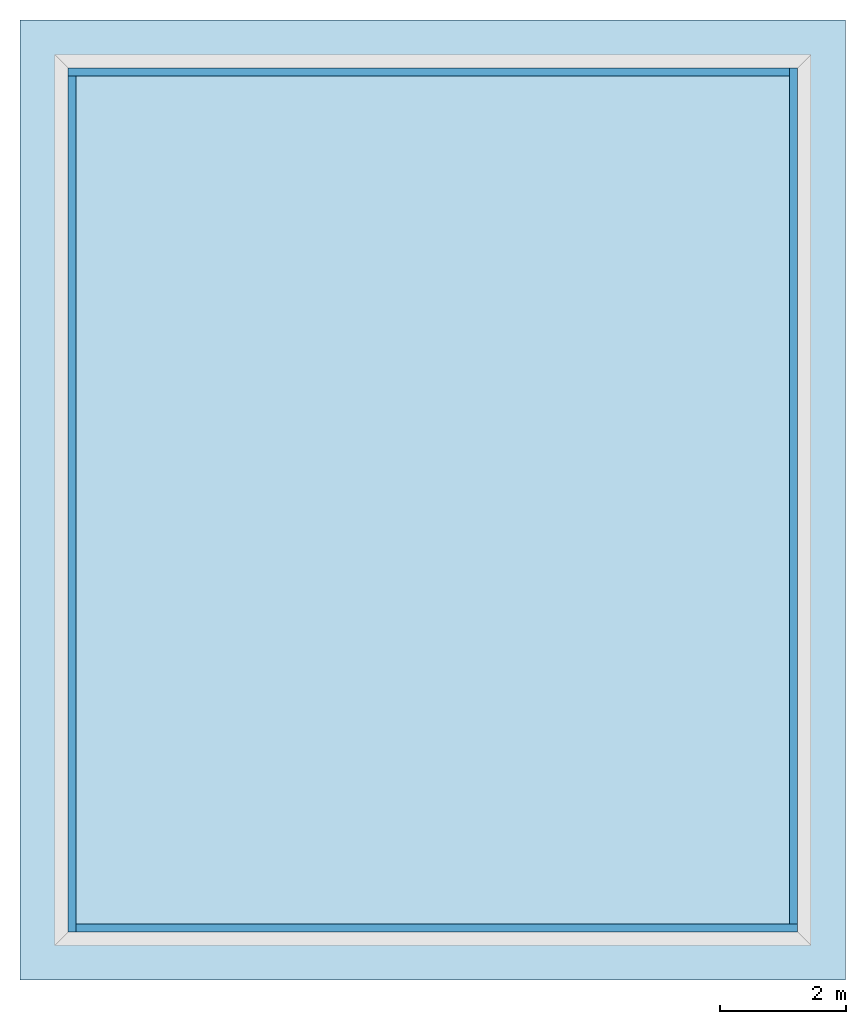
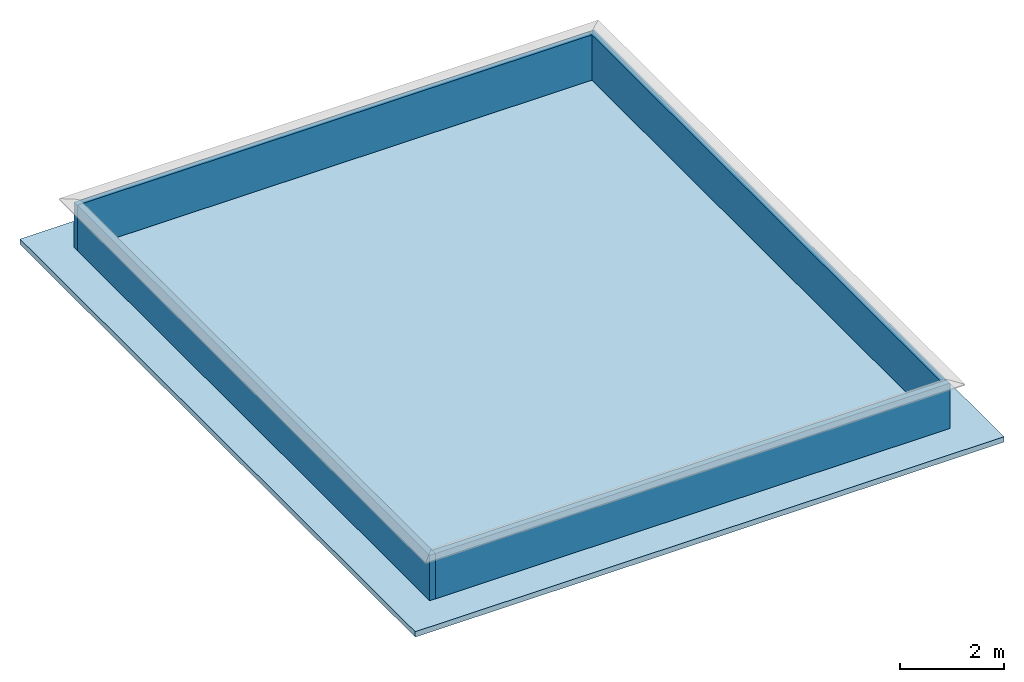
# One storey, part 1 of 2: 4 walls, 1 slab.
"""IFC2X3 building model written with IfcOpenShell, lengths in feet."""

from ifc_helpers import new_model, entity, si_unit, converted_unit, derived_unit, direction, frame, frame_2d, origin, origin_2d_with_axis, place, context, subcontext, project, spatial, rectangle, extrude, material, layer, layer_set, layer_usage, type_object, element, save


model = new_model("IFC2X3")

# Units and contexts
model_context = context("Model", 3, precision=0.0001, world=origin(), true_north=direction((6.123031769111886e-17, 1.0)))
body_context = subcontext(model_context, "Body", "Model", "MODEL_VIEW")
ifc_project = project(units=[converted_unit("LENGTHUNIT", "FOOT", entity("IfcLengthMeasure", 0.3048), si_unit("LENGTHUNIT", "METRE"), dimensions=[1, 0, 0, 0, 0, 0, 0]), converted_unit("AREAUNIT", "SQUARE FOOT", entity("IfcAreaMeasure", 0.09290304), si_unit("AREAUNIT", "SQUARE_METRE"), dimensions=[2, 0, 0, 0, 0, 0, 0]), converted_unit("VOLUMEUNIT", "CUBIC FOOT", entity("IfcVolumeMeasure", 0.028316846592000004), si_unit("VOLUMEUNIT", "CUBIC_METRE"), dimensions=[3, 0, 0, 0, 0, 0, 0]), converted_unit("PLANEANGLEUNIT", "DEGREE", entity("IfcPlaneAngleMeasure", 0.017453292519943278), si_unit("PLANEANGLEUNIT", "RADIAN"), dimensions=[0, 0, 0, 0, 0, 0, 0]), si_unit("MASSUNIT", "GRAM", prefix="KILO"), derived_unit("MASSDENSITYUNIT", [(si_unit("MASSUNIT", "GRAM", prefix="KILO"), 1), (si_unit("LENGTHUNIT", "METRE"), -3)]), derived_unit("IONCONCENTRATIONUNIT", [(si_unit("MASSUNIT", "GRAM", prefix="KILO"), 1), (si_unit("LENGTHUNIT", "METRE"), -3)]), derived_unit("MOMENTOFINERTIAUNIT", [(si_unit("LENGTHUNIT", "METRE"), 4)]), si_unit("TIMEUNIT", "SECOND"), si_unit("FREQUENCYUNIT", "HERTZ"), si_unit("THERMODYNAMICTEMPERATUREUNIT", "DEGREE_CELSIUS"), derived_unit("THERMALTRANSMITTANCEUNIT", [(si_unit("MASSUNIT", "GRAM", prefix="KILO"), 1), (si_unit("THERMODYNAMICTEMPERATUREUNIT", "KELVIN"), -1), (si_unit("TIMEUNIT", "SECOND"), -3)]), derived_unit("THERMALCONDUCTANCEUNIT", [(si_unit("MASSUNIT", "GRAM", prefix="KILO"), 1), (si_unit("THERMODYNAMICTEMPERATUREUNIT", "KELVIN"), -1), (si_unit("TIMEUNIT", "SECOND"), -3), (si_unit("LENGTHUNIT", "METRE"), 1)]), derived_unit("VOLUMETRICFLOWRATEUNIT", [(si_unit("LENGTHUNIT", "METRE"), 3), (si_unit("TIMEUNIT", "SECOND"), -1)]), derived_unit("MASSFLOWRATEUNIT", [(si_unit("MASSUNIT", "GRAM", prefix="KILO"), 1), (si_unit("TIMEUNIT", "SECOND"), -1)]), derived_unit("ROTATIONALFREQUENCYUNIT", [(si_unit("TIMEUNIT", "SECOND"), -1)]), si_unit("ELECTRICCURRENTUNIT", "AMPERE"), si_unit("ELECTRICVOLTAGEUNIT", "VOLT"), si_unit("POWERUNIT", "WATT"), converted_unit("FORCEUNIT", "KIP", entity("IfcForceMeasure", 2.088543423315013e-05), si_unit("FORCEUNIT", "NEWTON"), dimensions=[1, 1, -2, 0, 0, 0, 0]), si_unit("ILLUMINANCEUNIT", "LUX"), si_unit("LUMINOUSFLUXUNIT", "LUMEN"), si_unit("LUMINOUSINTENSITYUNIT", "CANDELA"), si_unit("ENERGYUNIT", "JOULE"), derived_unit("USERDEFINED", [(si_unit("MASSUNIT", "GRAM", prefix="KILO"), -1), (si_unit("LENGTHUNIT", "METRE"), -2), (si_unit("TIMEUNIT", "SECOND"), 3), (si_unit("LUMINOUSFLUXUNIT", "LUMEN"), 1)]), derived_unit("USERDEFINED", [(si_unit("MASSUNIT", "GRAM", prefix="KILO"), 1), (si_unit("TIMEUNIT", "SECOND"), -3), (si_unit("LENGTHUNIT", "METRE"), 3), (si_unit("ELECTRICCURRENTUNIT", "AMPERE"), -2)]), derived_unit("SOUNDPOWERUNIT", [(si_unit("MASSUNIT", "GRAM", prefix="KILO"), 1), (si_unit("TIMEUNIT", "SECOND"), -3), (si_unit("LENGTHUNIT", "METRE"), 2)]), derived_unit("SOUNDPRESSUREUNIT", [(si_unit("MASSUNIT", "GRAM", prefix="KILO"), 1), (si_unit("LENGTHUNIT", "METRE"), -1), (si_unit("TIMEUNIT", "SECOND"), -2)]), derived_unit("LINEARVELOCITYUNIT", [(si_unit("LENGTHUNIT", "METRE"), 1), (si_unit("TIMEUNIT", "SECOND"), -1)]), si_unit("PRESSUREUNIT", "PASCAL"), derived_unit("USERDEFINED", [(si_unit("MASSUNIT", "GRAM", prefix="KILO"), 1), (si_unit("LENGTHUNIT", "METRE"), -2), (si_unit("TIMEUNIT", "SECOND"), -2)]), derived_unit("LINEARFORCEUNIT", [(si_unit("MASSUNIT", "GRAM", prefix="KILO"), 1), (si_unit("TIMEUNIT", "SECOND"), -2)]), derived_unit("PLANARFORCEUNIT", [(si_unit("MASSUNIT", "GRAM", prefix="KILO"), 1), (si_unit("LENGTHUNIT", "METRE"), -1), (si_unit("TIMEUNIT", "SECOND"), -2)]), derived_unit("SPECIFICHEATCAPACITYUNIT", [(si_unit("THERMODYNAMICTEMPERATUREUNIT", "KELVIN"), -1), (si_unit("LENGTHUNIT", "METRE"), 2), (si_unit("TIMEUNIT", "SECOND"), -2)]), derived_unit("HEATFLUXDENSITYUNIT", [(si_unit("MASSUNIT", "GRAM", prefix="KILO"), 1), (si_unit("TIMEUNIT", "SECOND"), -3)]), derived_unit("HEATINGVALUEUNIT", [(si_unit("LENGTHUNIT", "METRE"), 2), (si_unit("TIMEUNIT", "SECOND"), -2)]), derived_unit("VAPORPERMEABILITYUNIT", [(si_unit("LENGTHUNIT", "METRE"), -1), (si_unit("TIMEUNIT", "SECOND"), 1)]), derived_unit("DYNAMICVISCOSITYUNIT", [(si_unit("MASSUNIT", "GRAM", prefix="KILO"), 1), (si_unit("TIMEUNIT", "SECOND"), -1), (si_unit("LENGTHUNIT", "METRE"), -1)]), derived_unit("THERMALEXPANSIONCOEFFICIENTUNIT", [(si_unit("THERMODYNAMICTEMPERATUREUNIT", "KELVIN"), -1)]), derived_unit("MODULUSOFELASTICITYUNIT", [(si_unit("MASSUNIT", "GRAM", prefix="KILO"), 1), (si_unit("LENGTHUNIT", "METRE"), -1), (si_unit("TIMEUNIT", "SECOND"), -2)]), derived_unit("ISOTHERMALMOISTURECAPACITYUNIT", [(si_unit("LENGTHUNIT", "METRE"), 3), (si_unit("MASSUNIT", "GRAM", prefix="KILO"), -1)]), derived_unit("MOISTUREDIFFUSIVITYUNIT", [(si_unit("TIMEUNIT", "SECOND"), -1), (si_unit("LENGTHUNIT", "METRE"), 2)]), derived_unit("MASSPERLENGTHUNIT", [(si_unit("MASSUNIT", "GRAM", prefix="KILO"), 1), (si_unit("LENGTHUNIT", "METRE"), -1)]), derived_unit("THERMALRESISTANCEUNIT", [(si_unit("MASSUNIT", "GRAM", prefix="KILO"), -1), (si_unit("TIMEUNIT", "SECOND"), 3), (si_unit("THERMODYNAMICTEMPERATUREUNIT", "KELVIN"), 1)]), derived_unit("ACCELERATIONUNIT", [(si_unit("LENGTHUNIT", "METRE"), 1), (si_unit("TIMEUNIT", "SECOND"), -2)]), derived_unit("ANGULARVELOCITYUNIT", [(si_unit("TIMEUNIT", "SECOND"), -1), (si_unit("PLANEANGLEUNIT", "RADIAN"), 1)]), derived_unit("LINEARSTIFFNESSUNIT", [(si_unit("MASSUNIT", "GRAM", prefix="KILO"), 1), (si_unit("TIMEUNIT", "SECOND"), -2)]), derived_unit("WARPINGCONSTANTUNIT", [(si_unit("LENGTHUNIT", "METRE"), 6)]), derived_unit("LINEARMOMENTUNIT", [(si_unit("MASSUNIT", "GRAM", prefix="KILO"), 1), (si_unit("LENGTHUNIT", "METRE"), 1), (si_unit("TIMEUNIT", "SECOND"), -2)]), derived_unit("TORQUEUNIT", [(si_unit("MASSUNIT", "GRAM", prefix="KILO"), 1), (si_unit("LENGTHUNIT", "METRE"), 2), (si_unit("TIMEUNIT", "SECOND"), -2)])], contexts=[model_context])

# Site, building, storey
site_placement = place(None, origin())
site = spatial("IfcSite", under=ifc_project, at=site_placement, CompositionType="ELEMENT")
building_placement = place(site_placement, origin())
building = spatial("IfcBuilding", under=site, at=building_placement, CompositionType="ELEMENT")
storey_placement = place(building_placement, frame((0.0, 0.0, 28.25000000000186)))
storey = spatial("IfcBuildingStorey", under=building, at=storey_placement, Name="Third Floor", CompositionType="ELEMENT", Elevation=28.25000000000186)

# Slab
ifc_material_1 = material(Name="Default Floor")
ifc_layer_1 = layer(ifc_material_1, 0.4166666666666667)
ifc_layer_set_1 = layer_set([ifc_layer_1])
ifc_layer_usage_1 = layer_usage(ifc_layer_set_1, "AXIS3", "POSITIVE", 0.0)
slab_type = type_object("IfcSlabType", PredefinedType="FLOOR", material=ifc_layer_set_1)
slab_placement = place(storey_placement, origin())
element("IfcSlab", 1, at=slab_placement, inside=storey, type_object=slab_type, material=ifc_layer_usage_1, PredefinedType="FLOOR", context=body_context, shape_type="SweptSolid", body=[
    extrude(rectangle(XDim=50.00000000000018, YDim=42.99999999999993, at=origin_2d_with_axis()), frame((28.874478019162204, -27.34124484724897, 0.0), z_axis=(0.0, 0.0, -1.0), x_axis=(0.0, 1.0, 0.0)), (0.0, 0.0, 1.0), 0.41666666666666785),
])

# Walls
ifc_material_2 = material(Name="Default Wall")
ifc_layer_2 = layer(ifc_material_2, 0.4166666666666667)
ifc_layer_set_2 = layer_set([ifc_layer_2], Name="Basic Wall:Parapet Wall")
ifc_layer_usage_2 = layer_usage(ifc_layer_set_2, "AXIS2", "NEGATIVE", 0.20833333333333334)
wall_type = type_object("IfcWallType", Name="Basic Wall:Parapet Wall", PredefinedType="STANDARD", material=ifc_layer_set_2)
wall_1_placement = place(storey_placement, frame((9.874478019163185, -5.049578180582901, 0.0)))
element("IfcWallStandardCase", 2, at=wall_1_placement, inside=storey, type_object=wall_type, material=ifc_layer_usage_2, Name="Basic Wall:Parapet Wall", ObjectType="Basic Wall:Parapet Wall", context=body_context, shape_type="SweptSolid", body=[
    extrude(rectangle(XDim=37.583333333333485, YDim=0.4166666666666661, at=frame_2d((18.791666666666742, 0.0), x_axis=(-1.0, 0.0))), origin(), (0.0, 0.0, 1.0), 3.5),
])
wall_2_placement = place(storey_placement, frame((10.08281135249652, -49.84124484724977, 0.0), z_axis=(0.0, 0.0, 1.0), x_axis=(0.0, 1.0, 0.0)))
element("IfcWallStandardCase", 3, at=wall_2_placement, inside=storey, type_object=wall_type, material=ifc_layer_usage_2, Name="Basic Wall:Parapet Wall", ObjectType="Basic Wall:Parapet Wall", context=body_context, shape_type="SweptSolid", body=[
    extrude(rectangle(XDim=44.583333333333535, YDim=0.41666666666666785, at=frame_2d((22.291666666666767, 0.0), x_axis=(-1.0, 0.0))), origin(), (0.0, 0.0, 1.0), 3.5),
])
wall_3_placement = place(storey_placement, frame((47.87447801916333, -49.63291151391643, 0.0), z_axis=(0.0, 0.0, 1.0), x_axis=(-1.0, 0.0, 0.0)))
element("IfcWallStandardCase", 4, at=wall_3_placement, inside=storey, type_object=wall_type, material=ifc_layer_usage_2, Name="Basic Wall:Parapet Wall", ObjectType="Basic Wall:Parapet Wall", context=body_context, shape_type="SweptSolid", body=[
    extrude(rectangle(XDim=37.58333333333347, YDim=0.4166666666666714, at=frame_2d((18.791666666666735, 0.0), x_axis=(-1.0, 0.0))), origin(), (0.0, 0.0, 1.0), 3.5),
])
wall_4_placement = place(storey_placement, frame((47.66614468583, -4.841244847249568, 0.0), z_axis=(0.0, 0.0, 1.0), x_axis=(0.0, -1.0, 0.0)))
element("IfcWallStandardCase", 5, at=wall_4_placement, inside=storey, type_object=wall_type, material=ifc_layer_usage_2, Name="Basic Wall:Parapet Wall", ObjectType="Basic Wall:Parapet Wall", context=body_context, shape_type="SweptSolid", body=[
    extrude(rectangle(XDim=44.583333333333535, YDim=0.4166666666666714, at=frame_2d((22.291666666666767, -5.551115123125783e-17), x_axis=(-1.0, 0.0))), origin(), (0.0, 0.0, 1.0), 3.5),
])

save(model, "model.ifc")
